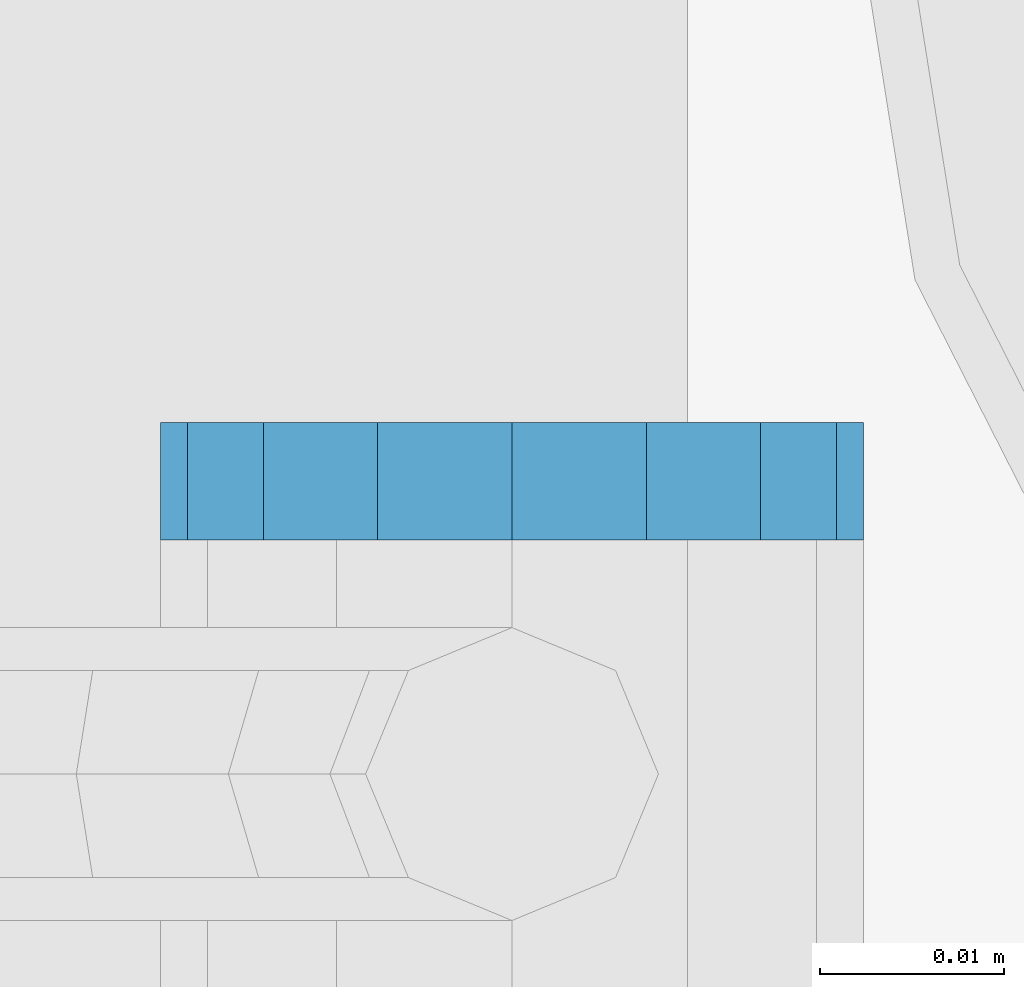
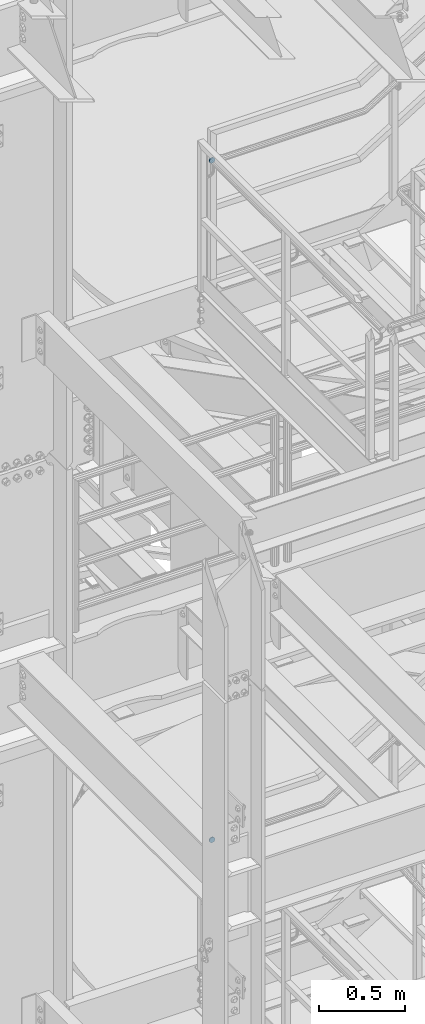
# One storey, part 1839 of 1876: 2 plates, 2 elements without a shape of their own.
"""IFC2X3 building model written with IfcOpenShell, lengths in millimetres."""

from ifc_helpers import new_model, si_unit, frame, origin_with_axes, place, context, subcontext, project, spatial, faceted_brep, material, type_object, element, aggregate, save


model = new_model("IFC2X3")

# Units and contexts
model_context = context("Model", 3, precision=1e-05, world=origin_with_axes())
body_context = subcontext(model_context, "Body", "Model", "MODEL_VIEW")
ifc_project = project(units=[si_unit("LENGTHUNIT", "METRE", prefix="MILLI"), si_unit("AREAUNIT", "SQUARE_METRE"), si_unit("VOLUMEUNIT", "CUBIC_METRE"), si_unit("MASSUNIT", "GRAM", prefix="KILO"), si_unit("TIMEUNIT", "SECOND"), si_unit("PLANEANGLEUNIT", "RADIAN"), si_unit("SOLIDANGLEUNIT", "STERADIAN"), si_unit("THERMODYNAMICTEMPERATUREUNIT", "DEGREE_CELSIUS"), si_unit("LUMINOUSINTENSITYUNIT", "LUMEN")], contexts=[model_context])

# Site, building, storey
site_placement = place(None, origin_with_axes())
site = spatial("IfcSite", under=ifc_project, at=site_placement, CompositionType="ELEMENT")
building_placement = place(site_placement, origin_with_axes())
building = spatial("IfcBuilding", under=site, at=building_placement, Name="Undefined", CompositionType="ELEMENT")
storey_placement = place(building_placement, origin_with_axes())
storey = spatial("IfcBuildingStorey", under=building, at=storey_placement, Name="Undefined", CompositionType="ELEMENT", Elevation=0.0)

# Assembly, plate
assembly_1_placement = place(storey_placement, origin_with_axes())
assembly_1 = element("IfcElementAssembly", 1, at=assembly_1_placement, inside=storey, Name="RAIL", AssemblyPlace="NOTDEFINED", PredefinedType="RIGID_FRAME")
ifc_material = material(Name="STEEL/A36")
plate_type = type_object("IfcPlateType", PredefinedType="NOTDEFINED")
plate_1_placement = place(assembly_1_placement, frame((1181.09999999374, -4848.22500191087, 16502.7316052369), z_axis=(0.0, 0.0, -1.0), x_axis=(-1.0, 0.0, 0.0)))
plate_1 = element("IfcPlate", 2, at=plate_1_placement, type_object=plate_type, material=ifc_material, Name="PLATE", context=body_context, shape_type="Brep", body=[
    faceted_brep([(0.0, -3.17500000000018, 19.0499992370605), (1.45009484758475, -3.17500000000018, 26.3401183316528), (1.45009484758475, 3.17500000000018, 26.3401183316528), (0.0, 3.17500000000018, 19.0499992370605), (5.57961559493651, -3.17500000000018, 32.5203828791855), (5.57961559493651, 3.17500000000018, 32.5203828791855), (11.7598801424699, -3.17500000000018, 36.6499036265377), (11.7598801424699, 3.17500000000018, 36.6499036265377), (19.0499992370605, -3.17500000000018, 38.0999984741211), (19.0499992370605, 3.17500000000018, 38.0999984741211), (26.3401183316512, -3.17500000000018, 36.6499036265377), (26.3401183316512, 3.17500000000018, 36.6499036265377), (32.5203828791846, -3.17500000000018, 32.5203828791855), (32.5203828791846, 3.17500000000018, 32.5203828791855), (36.6499036265363, -3.17500000000018, 26.3401183316528), (36.6499036265363, 3.17500000000018, 26.3401183316528), (38.0999984741211, -3.17500000000018, 19.0499992370605), (38.0999984741211, 3.17500000000018, 19.0499992370605), (36.6499036265363, -3.17500000000018, 11.7598801424683), (36.6499036265363, 3.17500000000018, 11.7598801424683), (32.5203828791846, -3.17500000000018, 5.5796155949356), (32.5203828791846, 3.17500000000018, 5.5796155949356), (26.3401183316512, -3.17500000000018, 1.45009484758339), (26.3401183316512, 3.17500000000018, 1.45009484758339), (19.0499992370706, -3.17499999999745, -3.63797880709171e-12), (19.0499992370678, 3.17499999999836, 3.63797880709171e-12), (11.7598801424699, -3.17500000000018, 1.45009484758339), (11.7598801424699, 3.17500000000018, 1.45009484758339), (5.57961559493651, -3.17500000000018, 5.5796155949356), (5.57961559493651, 3.17500000000018, 5.5796155949356), (1.45009484758475, -3.17500000000018, 11.7598801424683), (1.45009484758475, 3.17500000000018, 11.7598801424683)], [[[0, 1, 2, 3]], [[1, 4, 5, 2]], [[4, 6, 7, 5]], [[6, 8, 9, 7]], [[8, 10, 11, 9]], [[10, 12, 13, 11]], [[12, 14, 15, 13]], [[14, 16, 17, 15]], [[16, 18, 19, 17]], [[18, 20, 21, 19]], [[20, 22, 23, 21]], [[22, 24, 25, 23]], [[24, 26, 27, 25]], [[26, 28, 29, 27]], [[28, 30, 31, 29]], [[30, 0, 3, 31]], [[5, 7, 9, 11, 13, 15, 17, 19, 21, 23, 25, 27, 29, 31, 3, 2]], [[30, 28, 26, 24, 22, 20, 18, 16, 14, 12, 10, 8, 6, 4, 1, 0]]]),
])
aggregate(assembly_1, [plate_1])

assembly_2_placement = place(storey_placement, origin_with_axes())
assembly_2 = element("IfcElementAssembly", 3, at=assembly_2_placement, inside=storey, Name="RAIL", AssemblyPlace="NOTDEFINED", PredefinedType="RIGID_FRAME")
plate_2_placement = place(assembly_2_placement, frame((1181.10000034225, -4848.22500191036, 11674.379753487), z_axis=(0.0, 0.0, -1.0), x_axis=(-1.0, 0.0, 0.0)))
plate_2 = element("IfcPlate", 4, at=plate_2_placement, type_object=plate_type, material=ifc_material, Name="PLATE", context=body_context, shape_type="Brep", body=[
    faceted_brep([(0.0, -3.17500000000018, 19.0499992370605), (1.45009484758475, -3.17500000000018, 26.3401183316528), (1.45009484758475, 3.17500000000018, 26.3401183316528), (0.0, 3.17500000000018, 19.0499992370605), (5.57961559493651, -3.17500000000018, 32.5203828791855), (5.57961559493651, 3.17500000000018, 32.5203828791855), (11.7598801424699, -3.17500000000018, 36.6499036265377), (11.7598801424699, 3.17500000000018, 36.6499036265377), (19.0499992370605, -3.17500000000018, 38.0999984741211), (19.0499992370605, 3.17500000000018, 38.0999984741211), (26.3401183316512, -3.17500000000018, 36.6499036265377), (26.3401183316512, 3.17500000000018, 36.6499036265377), (32.5203828791846, -3.17500000000018, 32.5203828791855), (32.5203828791846, 3.17500000000018, 32.5203828791855), (36.6499036265363, -3.17500000000018, 26.3401183316528), (36.6499036265363, 3.17500000000018, 26.3401183316528), (38.0999984741211, -3.17500000000018, 19.0499992370605), (38.0999984741211, 3.17500000000018, 19.0499992370605), (36.6499036265363, -3.17500000000018, 11.7598801424683), (36.6499036265363, 3.17500000000018, 11.7598801424683), (32.5203828791846, -3.17500000000018, 5.5796155949356), (32.5203828791846, 3.17500000000018, 5.5796155949356), (26.3401183316512, -3.17500000000018, 1.45009484758339), (26.3401183316512, 3.17500000000018, 1.45009484758339), (19.0499992370706, -3.17499999999745, -3.63797880709171e-12), (19.0499992370678, 3.17499999999836, 3.63797880709171e-12), (11.7598801424699, -3.17500000000018, 1.45009484758339), (11.7598801424699, 3.17500000000018, 1.45009484758339), (5.57961559493651, -3.17500000000018, 5.5796155949356), (5.57961559493651, 3.17500000000018, 5.5796155949356), (1.45009484758475, -3.17500000000018, 11.7598801424683), (1.45009484758475, 3.17500000000018, 11.7598801424683)], [[[0, 1, 2, 3]], [[1, 4, 5, 2]], [[4, 6, 7, 5]], [[6, 8, 9, 7]], [[8, 10, 11, 9]], [[10, 12, 13, 11]], [[12, 14, 15, 13]], [[14, 16, 17, 15]], [[16, 18, 19, 17]], [[18, 20, 21, 19]], [[20, 22, 23, 21]], [[22, 24, 25, 23]], [[24, 26, 27, 25]], [[26, 28, 29, 27]], [[28, 30, 31, 29]], [[30, 0, 3, 31]], [[5, 7, 9, 11, 13, 15, 17, 19, 21, 23, 25, 27, 29, 31, 3, 2]], [[30, 28, 26, 24, 22, 20, 18, 16, 14, 12, 10, 8, 6, 4, 1, 0]]]),
])
aggregate(assembly_2, [plate_2])

save(model, "model.ifc")
